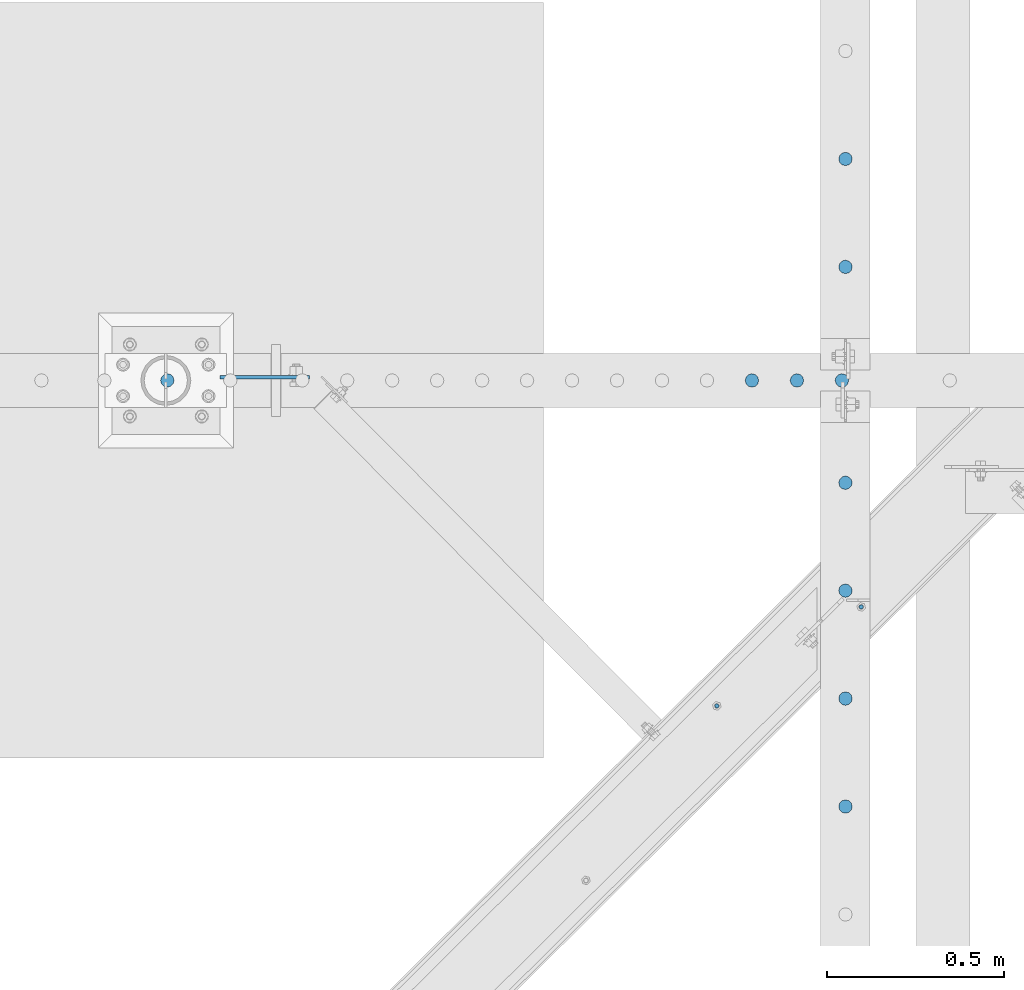
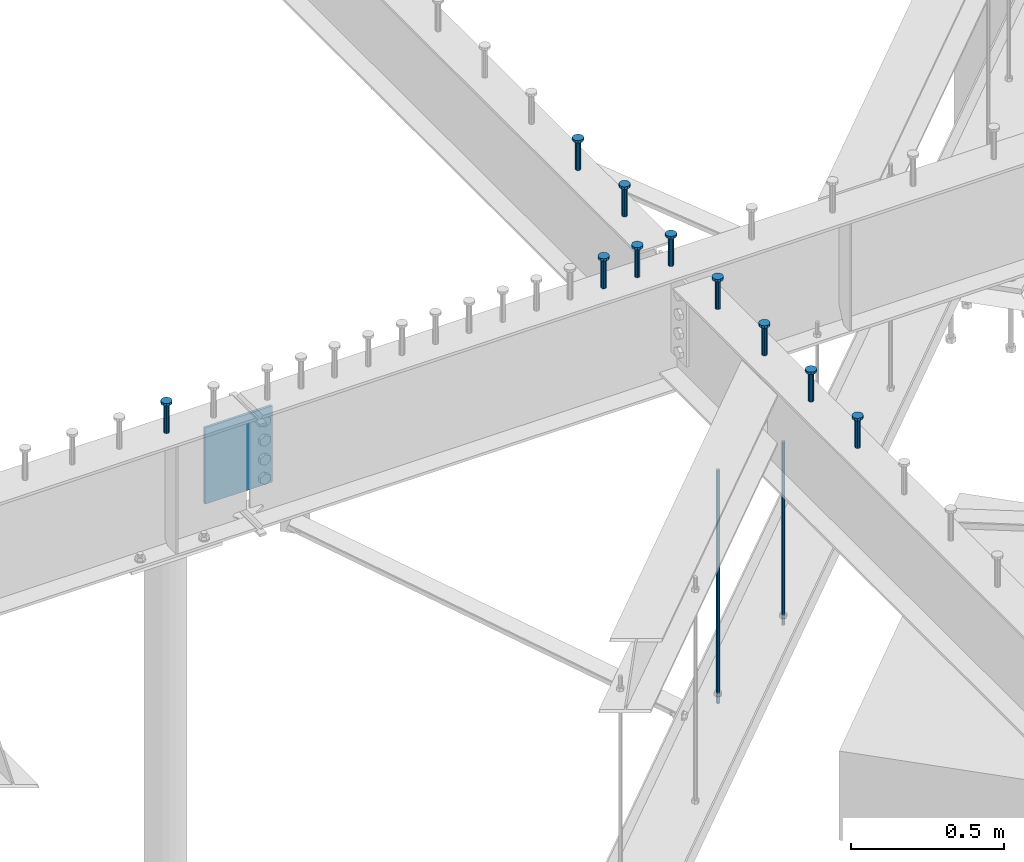
# One storey, part 206 of 975: 13 columns.
"""IFC2X3 building model written with IfcOpenShell, lengths in millimetres."""

from ifc_helpers import new_model, si_unit, frame, origin_with_axes, place, context, subcontext, project, spatial, faceted_brep, material, type_object, element, save


model = new_model("IFC2X3")

# Units and contexts
model_context = context("Model", 3, precision=1e-05, world=origin_with_axes())
body_context = subcontext(model_context, "Body", "Model", "MODEL_VIEW")
ifc_project = project(units=[si_unit("LENGTHUNIT", "METRE", prefix="MILLI"), si_unit("AREAUNIT", "SQUARE_METRE"), si_unit("VOLUMEUNIT", "CUBIC_METRE"), si_unit("MASSUNIT", "GRAM", prefix="KILO"), si_unit("TIMEUNIT", "SECOND"), si_unit("PLANEANGLEUNIT", "RADIAN"), si_unit("SOLIDANGLEUNIT", "STERADIAN"), si_unit("THERMODYNAMICTEMPERATUREUNIT", "DEGREE_CELSIUS"), si_unit("LUMINOUSINTENSITYUNIT", "LUMEN")], contexts=[model_context])

# Site, building, storey
site_placement = place(None, origin_with_axes())
site = spatial("IfcSite", under=ifc_project, at=site_placement, CompositionType="ELEMENT")
building_placement = place(site_placement, origin_with_axes())
building = spatial("IfcBuilding", under=site, at=building_placement, Name="Undefined", CompositionType="ELEMENT")
storey_placement = place(building_placement, origin_with_axes())
storey = spatial("IfcBuildingStorey", under=building, at=storey_placement, Name="Undefined", CompositionType="ELEMENT", Elevation=0.0)

# Columns
ifc_material_1 = material(Name="STEEL/A36")
column_type_1 = type_object("IfcColumnType", PredefinedType="NOTDEFINED")
column_1_placement = place(storey_placement, frame((26689.0500000226, 12752.6443848371, 2870.2), z_axis=(-0.705007718837806, 0.709199630836842, 0.0), x_axis=(0.0, 0.0, 1.0)))
element("IfcColumn", 1, at=column_1_placement, inside=storey, type_object=column_type_1, material=ifc_material_1, Name="ALL-THREAD ROD", context=body_context, shape_type="Brep", body=[
    faceted_brep([(0.0, -6.34999999998763, -3.63797880709171e-12), (0.0, -4.49012806052269, -4.49012806054634), (731.8375, -4.49012806052269, -4.49012806054998), (731.8375, -6.34999999999127, -7.27595761418343e-12), (0.0, 7.27595761418343e-12, -6.35000000000764), (731.8375, 7.27595761418343e-12, -6.35000000000946), (0.0, 4.49012806053724, -4.49012806053906), (731.8375, 4.49012806053724, -4.49012806053906), (0.0, 6.34999999999491, 5.45696821063757e-12), (731.8375, 6.34999999999491, 1.81898940354586e-12), (0.0, 4.49012806052633, 4.49012806054634), (731.8375, 4.49012806052997, 4.49012806054452), (0.0, 0.0, 6.35000000000764), (731.8375, -3.63797880709171e-12, 6.35000000000946), (0.0, -4.49012806053361, 4.49012806053543), (731.8375, -4.49012806052997, 4.49012806053724)], [[[0, 1, 2, 3]], [[1, 4, 5, 2]], [[4, 6, 7, 5]], [[6, 8, 9, 7]], [[8, 10, 11, 9]], [[10, 12, 13, 11]], [[12, 14, 15, 13]], [[14, 0, 3, 15]], [[5, 7, 9, 11, 13, 15, 3, 2]], [[14, 12, 10, 8, 6, 4, 1, 0]]]),
])
column_2_placement = place(storey_placement, frame((26281.5235994516, 12472.939904784, 2870.2), z_axis=(-0.705007718837806, 0.709199630836842, 0.0), x_axis=(0.0, 0.0, 1.0)))
element("IfcColumn", 2, at=column_2_placement, inside=storey, type_object=column_type_1, material=ifc_material_1, Name="ALL-THREAD ROD", context=body_context, shape_type="Brep", body=[
    faceted_brep([(0.0, -6.34999999998763, -3.63797880709171e-12), (0.0, -4.49012806052269, -4.49012806054634), (931.8625, -4.49012806052269, -4.49012806054634), (931.8625, -6.34999999998763, -3.63797880709171e-12), (0.0, 7.27595761418343e-12, -6.35000000000764), (931.8625, 7.27595761418343e-12, -6.35000000000764), (0.0, 4.49012806053724, -4.49012806053906), (931.8625, 4.49012806053724, -4.49012806053906), (0.0, 6.34999999999491, 5.45696821063757e-12), (931.8625, 6.34999999999491, 5.45696821063757e-12), (0.0, 4.49012806052633, 4.49012806054634), (931.8625, 4.49012806052633, 4.49012806054634), (0.0, 0.0, 6.35000000000764), (931.8625, 0.0, 6.35000000000764), (0.0, -4.49012806053361, 4.49012806053543), (931.8625, -4.49012806053361, 4.49012806053543)], [[[0, 1, 2, 3]], [[1, 4, 5, 2]], [[4, 6, 7, 5]], [[6, 8, 9, 7]], [[8, 10, 11, 9]], [[10, 12, 13, 11]], [[12, 14, 15, 13]], [[14, 0, 3, 15]], [[5, 7, 9, 11, 13, 15, 3, 2]], [[14, 12, 10, 8, 6, 4, 1, 0]]]),
])
ifc_material_2 = material(Name="STEEL/A108")
column_type_2 = type_object("IfcColumnType", Name="STUD_3/4-DIA", PredefinedType="NOTDEFINED")
column_3_placement = place(storey_placement, frame((26644.6662714101, 14017.625, 3937.0), z_axis=(0.0, 1.0, 0.0), x_axis=(0.0, 0.0, 1.0)))
element("IfcColumn", 3, at=column_3_placement, inside=storey, type_object=column_type_2, material=ifc_material_2, ObjectType="STUD_3/4-DIA", context=body_context, shape_type="Brep", body=[
    faceted_brep([(0.0, -9.52000045776367, 0.0), (0.0, -8.25, -4.76000022888184), (115.57, -8.25, -4.76000022888184), (115.57, -9.52000045776367, 0.0), (0.0, -4.76000022888184, -8.25), (115.57, -4.76000022888184, -8.25), (0.0, 0.0, -9.52000045776367), (115.57, 0.0, -9.52000045776367), (0.0, 4.76000022888184, -8.25), (115.57, 4.76000022888184, -8.25), (0.0, 8.25, -4.76000022888184), (115.57, 8.25, -4.76000022888184), (0.0, 9.52000045776367, 0.0), (115.57, 9.52000045776367, 0.0), (0.0, 8.25, 4.76000022888184), (115.57, 8.25, 4.76000022888184), (0.0, 4.76000022888184, 8.25), (115.57, 4.76000022888184, 8.25), (0.0, 0.0, 9.52000045776367), (115.57, 0.0, 9.52000045776367), (0.0, -4.76000022888184, 8.25), (115.57, -4.76000022888184, 8.25), (0.0, -8.25, 4.76000022888184), (115.57, -8.25, 4.76000022888184), (116.84, -16.5, -9.52000045776367), (116.84, -19.0499992370605, 0.0), (116.84, -9.52000045776367, -16.5), (116.84, 0.0, -19.0499992370605), (116.84, 9.52000045776367, -16.5), (116.84, 16.5, -9.52000045776367), (116.84, 19.0499992370605, 0.0), (116.84, 16.5, 9.52000045776367), (116.84, 9.52000045776367, 16.5), (116.84, 0.0, 19.0499992370605), (116.84, -9.52000045776367, 16.5), (116.84, -16.5, 9.52000045776367), (127.0, -16.5, -9.52000045776367), (127.0, -19.0499992370605, 0.0), (127.0, -9.52000045776367, -16.5), (127.0, 0.0, -19.0499992370605), (127.0, 9.52000045776367, -16.5), (127.0, 16.5, -9.52000045776367), (127.0, 19.0499992370605, 0.0), (127.0, 16.5, 9.52000045776367), (127.0, 9.52000045776367, 16.5), (127.0, 0.0, 19.0499992370605), (127.0, -9.52000045776367, 16.5), (127.0, -16.5, 9.52000045776367)], [[[0, 1, 2, 3]], [[1, 4, 5, 2]], [[4, 6, 7, 5]], [[6, 8, 9, 7]], [[8, 10, 11, 9]], [[10, 12, 13, 11]], [[12, 14, 15, 13]], [[14, 16, 17, 15]], [[16, 18, 19, 17]], [[18, 20, 21, 19]], [[20, 22, 23, 21]], [[22, 0, 3, 23]], [[22, 20, 18, 16, 14, 12, 10, 8, 6, 4, 1, 0]], [[3, 2, 24, 25]], [[2, 5, 26, 24]], [[5, 7, 27, 26]], [[7, 9, 28, 27]], [[9, 11, 29, 28]], [[11, 13, 30, 29]], [[13, 15, 31, 30]], [[15, 17, 32, 31]], [[17, 19, 33, 32]], [[19, 21, 34, 33]], [[21, 23, 35, 34]], [[23, 3, 25, 35]], [[25, 24, 36, 37]], [[24, 26, 38, 36]], [[26, 27, 39, 38]], [[27, 28, 40, 39]], [[28, 29, 41, 40]], [[29, 30, 42, 41]], [[30, 31, 43, 42]], [[31, 32, 44, 43]], [[32, 33, 45, 44]], [[33, 34, 46, 45]], [[34, 35, 47, 46]], [[35, 25, 37, 47]], [[38, 39, 40, 41, 42, 43, 44, 45, 46, 47, 37, 36]]]),
])
column_4_placement = place(storey_placement, frame((26644.6662714101, 13712.825, 3937.0), z_axis=(0.0, 1.0, 0.0), x_axis=(0.0, 0.0, 1.0)))
element("IfcColumn", 4, at=column_4_placement, inside=storey, type_object=column_type_2, material=ifc_material_2, ObjectType="STUD_3/4-DIA", context=body_context, shape_type="Brep", body=[
    faceted_brep([(0.0, -9.52000045776367, 0.0), (0.0, -8.25, -4.76000022888184), (115.57, -8.25, -4.76000022888184), (115.57, -9.52000045776367, 0.0), (0.0, -4.76000022888184, -8.25), (115.57, -4.76000022888184, -8.25), (0.0, 0.0, -9.52000045776367), (115.57, 0.0, -9.52000045776367), (0.0, 4.76000022888184, -8.25), (115.57, 4.76000022888184, -8.25), (0.0, 8.25, -4.76000022888184), (115.57, 8.25, -4.76000022888184), (0.0, 9.52000045776367, 0.0), (115.57, 9.52000045776367, 0.0), (0.0, 8.25, 4.76000022888184), (115.57, 8.25, 4.76000022888184), (0.0, 4.76000022888184, 8.25), (115.57, 4.76000022888184, 8.25), (0.0, 0.0, 9.52000045776367), (115.57, 0.0, 9.52000045776367), (0.0, -4.76000022888184, 8.25), (115.57, -4.76000022888184, 8.25), (0.0, -8.25, 4.76000022888184), (115.57, -8.25, 4.76000022888184), (116.84, -16.5, -9.52000045776367), (116.84, -19.0499992370605, 0.0), (116.84, -9.52000045776367, -16.5), (116.84, 0.0, -19.0499992370605), (116.84, 9.52000045776367, -16.5), (116.84, 16.5, -9.52000045776367), (116.84, 19.0499992370605, 0.0), (116.84, 16.5, 9.52000045776367), (116.84, 9.52000045776367, 16.5), (116.84, 0.0, 19.0499992370605), (116.84, -9.52000045776367, 16.5), (116.84, -16.5, 9.52000045776367), (127.0, -16.5, -9.52000045776367), (127.0, -19.0499992370605, 0.0), (127.0, -9.52000045776367, -16.5), (127.0, 0.0, -19.0499992370605), (127.0, 9.52000045776367, -16.5), (127.0, 16.5, -9.52000045776367), (127.0, 19.0499992370605, 0.0), (127.0, 16.5, 9.52000045776367), (127.0, 9.52000045776367, 16.5), (127.0, 0.0, 19.0499992370605), (127.0, -9.52000045776367, 16.5), (127.0, -16.5, 9.52000045776367)], [[[0, 1, 2, 3]], [[1, 4, 5, 2]], [[4, 6, 7, 5]], [[6, 8, 9, 7]], [[8, 10, 11, 9]], [[10, 12, 13, 11]], [[12, 14, 15, 13]], [[14, 16, 17, 15]], [[16, 18, 19, 17]], [[18, 20, 21, 19]], [[20, 22, 23, 21]], [[22, 0, 3, 23]], [[22, 20, 18, 16, 14, 12, 10, 8, 6, 4, 1, 0]], [[3, 2, 24, 25]], [[2, 5, 26, 24]], [[5, 7, 27, 26]], [[7, 9, 28, 27]], [[9, 11, 29, 28]], [[11, 13, 30, 29]], [[13, 15, 31, 30]], [[15, 17, 32, 31]], [[17, 19, 33, 32]], [[19, 21, 34, 33]], [[21, 23, 35, 34]], [[23, 3, 25, 35]], [[25, 24, 36, 37]], [[24, 26, 38, 36]], [[26, 27, 39, 38]], [[27, 28, 40, 39]], [[28, 29, 41, 40]], [[29, 30, 42, 41]], [[30, 31, 43, 42]], [[31, 32, 44, 43]], [[32, 33, 45, 44]], [[33, 34, 46, 45]], [[34, 35, 47, 46]], [[35, 25, 37, 47]], [[38, 39, 40, 41, 42, 43, 44, 45, 46, 47, 37, 36]]]),
])
column_5_placement = place(storey_placement, frame((26644.6662714101, 13103.225, 3937.0), z_axis=(0.0, 1.0, 0.0), x_axis=(0.0, 0.0, 1.0)))
element("IfcColumn", 5, at=column_5_placement, inside=storey, type_object=column_type_2, material=ifc_material_2, ObjectType="STUD_3/4-DIA", context=body_context, shape_type="Brep", body=[
    faceted_brep([(0.0, -9.52000045776367, 0.0), (0.0, -8.25, -4.76000022888184), (115.57, -8.25, -4.76000022888184), (115.57, -9.52000045776367, 0.0), (0.0, -4.76000022888184, -8.25), (115.57, -4.76000022888184, -8.25), (0.0, 0.0, -9.52000045776367), (115.57, 0.0, -9.52000045776367), (0.0, 4.76000022888184, -8.25), (115.57, 4.76000022888184, -8.25), (0.0, 8.25, -4.76000022888184), (115.57, 8.25, -4.76000022888184), (0.0, 9.52000045776367, 0.0), (115.57, 9.52000045776367, 0.0), (0.0, 8.25, 4.76000022888184), (115.57, 8.25, 4.76000022888184), (0.0, 4.76000022888184, 8.25), (115.57, 4.76000022888184, 8.25), (0.0, 0.0, 9.52000045776367), (115.57, 0.0, 9.52000045776367), (0.0, -4.76000022888184, 8.25), (115.57, -4.76000022888184, 8.25), (0.0, -8.25, 4.76000022888184), (115.57, -8.25, 4.76000022888184), (116.84, -16.5, -9.52000045776367), (116.84, -19.0499992370605, 0.0), (116.84, -9.52000045776367, -16.5), (116.84, 0.0, -19.0499992370605), (116.84, 9.52000045776367, -16.5), (116.84, 16.5, -9.52000045776367), (116.84, 19.0499992370605, 0.0), (116.84, 16.5, 9.52000045776367), (116.84, 9.52000045776367, 16.5), (116.84, 0.0, 19.0499992370605), (116.84, -9.52000045776367, 16.5), (116.84, -16.5, 9.52000045776367), (127.0, -16.5, -9.52000045776367), (127.0, -19.0499992370605, 0.0), (127.0, -9.52000045776367, -16.5), (127.0, 0.0, -19.0499992370605), (127.0, 9.52000045776367, -16.5), (127.0, 16.5, -9.52000045776367), (127.0, 19.0499992370605, 0.0), (127.0, 16.5, 9.52000045776367), (127.0, 9.52000045776367, 16.5), (127.0, 0.0, 19.0499992370605), (127.0, -9.52000045776367, 16.5), (127.0, -16.5, 9.52000045776367)], [[[0, 1, 2, 3]], [[1, 4, 5, 2]], [[4, 6, 7, 5]], [[6, 8, 9, 7]], [[8, 10, 11, 9]], [[10, 12, 13, 11]], [[12, 14, 15, 13]], [[14, 16, 17, 15]], [[16, 18, 19, 17]], [[18, 20, 21, 19]], [[20, 22, 23, 21]], [[22, 0, 3, 23]], [[22, 20, 18, 16, 14, 12, 10, 8, 6, 4, 1, 0]], [[3, 2, 24, 25]], [[2, 5, 26, 24]], [[5, 7, 27, 26]], [[7, 9, 28, 27]], [[9, 11, 29, 28]], [[11, 13, 30, 29]], [[13, 15, 31, 30]], [[15, 17, 32, 31]], [[17, 19, 33, 32]], [[19, 21, 34, 33]], [[21, 23, 35, 34]], [[23, 3, 25, 35]], [[25, 24, 36, 37]], [[24, 26, 38, 36]], [[26, 27, 39, 38]], [[27, 28, 40, 39]], [[28, 29, 41, 40]], [[29, 30, 42, 41]], [[30, 31, 43, 42]], [[31, 32, 44, 43]], [[32, 33, 45, 44]], [[33, 34, 46, 45]], [[34, 35, 47, 46]], [[35, 25, 37, 47]], [[38, 39, 40, 41, 42, 43, 44, 45, 46, 47, 37, 36]]]),
])
column_6_placement = place(storey_placement, frame((26644.6662714101, 12798.425, 3937.0), z_axis=(0.0, 1.0, 0.0), x_axis=(0.0, 0.0, 1.0)))
element("IfcColumn", 6, at=column_6_placement, inside=storey, type_object=column_type_2, material=ifc_material_2, ObjectType="STUD_3/4-DIA", context=body_context, shape_type="Brep", body=[
    faceted_brep([(0.0, -9.52000045776367, 0.0), (0.0, -8.25, -4.76000022888184), (115.57, -8.25, -4.76000022888184), (115.57, -9.52000045776367, 0.0), (0.0, -4.76000022888184, -8.25), (115.57, -4.76000022888184, -8.25), (0.0, 0.0, -9.52000045776367), (115.57, 0.0, -9.52000045776367), (0.0, 4.76000022888184, -8.25), (115.57, 4.76000022888184, -8.25), (0.0, 8.25, -4.76000022888184), (115.57, 8.25, -4.76000022888184), (0.0, 9.52000045776367, 0.0), (115.57, 9.52000045776367, 0.0), (0.0, 8.25, 4.76000022888184), (115.57, 8.25, 4.76000022888184), (0.0, 4.76000022888184, 8.25), (115.57, 4.76000022888184, 8.25), (0.0, 0.0, 9.52000045776367), (115.57, 0.0, 9.52000045776367), (0.0, -4.76000022888184, 8.25), (115.57, -4.76000022888184, 8.25), (0.0, -8.25, 4.76000022888184), (115.57, -8.25, 4.76000022888184), (116.84, -16.5, -9.52000045776367), (116.84, -19.0499992370605, 0.0), (116.84, -9.52000045776367, -16.5), (116.84, 0.0, -19.0499992370605), (116.84, 9.52000045776367, -16.5), (116.84, 16.5, -9.52000045776367), (116.84, 19.0499992370605, 0.0), (116.84, 16.5, 9.52000045776367), (116.84, 9.52000045776367, 16.5), (116.84, 0.0, 19.0499992370605), (116.84, -9.52000045776367, 16.5), (116.84, -16.5, 9.52000045776367), (127.0, -16.5, -9.52000045776367), (127.0, -19.0499992370605, 0.0), (127.0, -9.52000045776367, -16.5), (127.0, 0.0, -19.0499992370605), (127.0, 9.52000045776367, -16.5), (127.0, 16.5, -9.52000045776367), (127.0, 19.0499992370605, 0.0), (127.0, 16.5, 9.52000045776367), (127.0, 9.52000045776367, 16.5), (127.0, 0.0, 19.0499992370605), (127.0, -9.52000045776367, 16.5), (127.0, -16.5, 9.52000045776367)], [[[0, 1, 2, 3]], [[1, 4, 5, 2]], [[4, 6, 7, 5]], [[6, 8, 9, 7]], [[8, 10, 11, 9]], [[10, 12, 13, 11]], [[12, 14, 15, 13]], [[14, 16, 17, 15]], [[16, 18, 19, 17]], [[18, 20, 21, 19]], [[20, 22, 23, 21]], [[22, 0, 3, 23]], [[22, 20, 18, 16, 14, 12, 10, 8, 6, 4, 1, 0]], [[3, 2, 24, 25]], [[2, 5, 26, 24]], [[5, 7, 27, 26]], [[7, 9, 28, 27]], [[9, 11, 29, 28]], [[11, 13, 30, 29]], [[13, 15, 31, 30]], [[15, 17, 32, 31]], [[17, 19, 33, 32]], [[19, 21, 34, 33]], [[21, 23, 35, 34]], [[23, 3, 25, 35]], [[25, 24, 36, 37]], [[24, 26, 38, 36]], [[26, 27, 39, 38]], [[27, 28, 40, 39]], [[28, 29, 41, 40]], [[29, 30, 42, 41]], [[30, 31, 43, 42]], [[31, 32, 44, 43]], [[32, 33, 45, 44]], [[33, 34, 46, 45]], [[34, 35, 47, 46]], [[35, 25, 37, 47]], [[38, 39, 40, 41, 42, 43, 44, 45, 46, 47, 37, 36]]]),
])
column_7_placement = place(storey_placement, frame((26644.6662714101, 12493.625, 3937.0), z_axis=(0.0, 1.0, 0.0), x_axis=(0.0, 0.0, 1.0)))
element("IfcColumn", 7, at=column_7_placement, inside=storey, type_object=column_type_2, material=ifc_material_2, ObjectType="STUD_3/4-DIA", context=body_context, shape_type="Brep", body=[
    faceted_brep([(0.0, -9.52000045776367, 0.0), (0.0, -8.25, -4.76000022888184), (115.57, -8.25, -4.76000022888184), (115.57, -9.52000045776367, 0.0), (0.0, -4.76000022888184, -8.25), (115.57, -4.76000022888184, -8.25), (0.0, 0.0, -9.52000045776367), (115.57, 0.0, -9.52000045776367), (0.0, 4.76000022888184, -8.25), (115.57, 4.76000022888184, -8.25), (0.0, 8.25, -4.76000022888184), (115.57, 8.25, -4.76000022888184), (0.0, 9.52000045776367, 0.0), (115.57, 9.52000045776367, 0.0), (0.0, 8.25, 4.76000022888184), (115.57, 8.25, 4.76000022888184), (0.0, 4.76000022888184, 8.25), (115.57, 4.76000022888184, 8.25), (0.0, 0.0, 9.52000045776367), (115.57, 0.0, 9.52000045776367), (0.0, -4.76000022888184, 8.25), (115.57, -4.76000022888184, 8.25), (0.0, -8.25, 4.76000022888184), (115.57, -8.25, 4.76000022888184), (116.84, -16.5, -9.52000045776367), (116.84, -19.0499992370605, 0.0), (116.84, -9.52000045776367, -16.5), (116.84, 0.0, -19.0499992370605), (116.84, 9.52000045776367, -16.5), (116.84, 16.5, -9.52000045776367), (116.84, 19.0499992370605, 0.0), (116.84, 16.5, 9.52000045776367), (116.84, 9.52000045776367, 16.5), (116.84, 0.0, 19.0499992370605), (116.84, -9.52000045776367, 16.5), (116.84, -16.5, 9.52000045776367), (127.0, -16.5, -9.52000045776367), (127.0, -19.0499992370605, 0.0), (127.0, -9.52000045776367, -16.5), (127.0, 0.0, -19.0499992370605), (127.0, 9.52000045776367, -16.5), (127.0, 16.5, -9.52000045776367), (127.0, 19.0499992370605, 0.0), (127.0, 16.5, 9.52000045776367), (127.0, 9.52000045776367, 16.5), (127.0, 0.0, 19.0499992370605), (127.0, -9.52000045776367, 16.5), (127.0, -16.5, 9.52000045776367)], [[[0, 1, 2, 3]], [[1, 4, 5, 2]], [[4, 6, 7, 5]], [[6, 8, 9, 7]], [[8, 10, 11, 9]], [[10, 12, 13, 11]], [[12, 14, 15, 13]], [[14, 16, 17, 15]], [[16, 18, 19, 17]], [[18, 20, 21, 19]], [[20, 22, 23, 21]], [[22, 0, 3, 23]], [[22, 20, 18, 16, 14, 12, 10, 8, 6, 4, 1, 0]], [[3, 2, 24, 25]], [[2, 5, 26, 24]], [[5, 7, 27, 26]], [[7, 9, 28, 27]], [[9, 11, 29, 28]], [[11, 13, 30, 29]], [[13, 15, 31, 30]], [[15, 17, 32, 31]], [[17, 19, 33, 32]], [[19, 21, 34, 33]], [[21, 23, 35, 34]], [[23, 3, 25, 35]], [[25, 24, 36, 37]], [[24, 26, 38, 36]], [[26, 27, 39, 38]], [[27, 28, 40, 39]], [[28, 29, 41, 40]], [[29, 30, 42, 41]], [[30, 31, 43, 42]], [[31, 32, 44, 43]], [[32, 33, 45, 44]], [[33, 34, 46, 45]], [[34, 35, 47, 46]], [[35, 25, 37, 47]], [[38, 39, 40, 41, 42, 43, 44, 45, 46, 47, 37, 36]]]),
])
column_8_placement = place(storey_placement, frame((26644.6662714101, 12188.825, 3937.0), z_axis=(0.0, 1.0, 0.0), x_axis=(0.0, 0.0, 1.0)))
element("IfcColumn", 8, at=column_8_placement, inside=storey, type_object=column_type_2, material=ifc_material_2, ObjectType="STUD_3/4-DIA", context=body_context, shape_type="Brep", body=[
    faceted_brep([(0.0, -9.52000045776367, 0.0), (0.0, -8.25, -4.76000022888184), (115.57, -8.25, -4.76000022888184), (115.57, -9.52000045776367, 0.0), (0.0, -4.76000022888184, -8.25), (115.57, -4.76000022888184, -8.25), (0.0, 0.0, -9.52000045776367), (115.57, 0.0, -9.52000045776367), (0.0, 4.76000022888184, -8.25), (115.57, 4.76000022888184, -8.25), (0.0, 8.25, -4.76000022888184), (115.57, 8.25, -4.76000022888184), (0.0, 9.52000045776367, 0.0), (115.57, 9.52000045776367, 0.0), (0.0, 8.25, 4.76000022888184), (115.57, 8.25, 4.76000022888184), (0.0, 4.76000022888184, 8.25), (115.57, 4.76000022888184, 8.25), (0.0, 0.0, 9.52000045776367), (115.57, 0.0, 9.52000045776367), (0.0, -4.76000022888184, 8.25), (115.57, -4.76000022888184, 8.25), (0.0, -8.25, 4.76000022888184), (115.57, -8.25, 4.76000022888184), (116.84, -16.5, -9.52000045776367), (116.84, -19.0499992370605, 0.0), (116.84, -9.52000045776367, -16.5), (116.84, 0.0, -19.0499992370605), (116.84, 9.52000045776367, -16.5), (116.84, 16.5, -9.52000045776367), (116.84, 19.0499992370605, 0.0), (116.84, 16.5, 9.52000045776367), (116.84, 9.52000045776367, 16.5), (116.84, 0.0, 19.0499992370605), (116.84, -9.52000045776367, 16.5), (116.84, -16.5, 9.52000045776367), (127.0, -16.5, -9.52000045776367), (127.0, -19.0499992370605, 0.0), (127.0, -9.52000045776367, -16.5), (127.0, 0.0, -19.0499992370605), (127.0, 9.52000045776367, -16.5), (127.0, 16.5, -9.52000045776367), (127.0, 19.0499992370605, 0.0), (127.0, 16.5, 9.52000045776367), (127.0, 9.52000045776367, 16.5), (127.0, 0.0, 19.0499992370605), (127.0, -9.52000045776367, 16.5), (127.0, -16.5, 9.52000045776367)], [[[0, 1, 2, 3]], [[1, 4, 5, 2]], [[4, 6, 7, 5]], [[6, 8, 9, 7]], [[8, 10, 11, 9]], [[10, 12, 13, 11]], [[12, 14, 15, 13]], [[14, 16, 17, 15]], [[16, 18, 19, 17]], [[18, 20, 21, 19]], [[20, 22, 23, 21]], [[22, 0, 3, 23]], [[22, 20, 18, 16, 14, 12, 10, 8, 6, 4, 1, 0]], [[3, 2, 24, 25]], [[2, 5, 26, 24]], [[5, 7, 27, 26]], [[7, 9, 28, 27]], [[9, 11, 29, 28]], [[11, 13, 30, 29]], [[13, 15, 31, 30]], [[15, 17, 32, 31]], [[17, 19, 33, 32]], [[19, 21, 34, 33]], [[21, 23, 35, 34]], [[23, 3, 25, 35]], [[25, 24, 36, 37]], [[24, 26, 38, 36]], [[26, 27, 39, 38]], [[27, 28, 40, 39]], [[28, 29, 41, 40]], [[29, 30, 42, 41]], [[30, 31, 43, 42]], [[31, 32, 44, 43]], [[32, 33, 45, 44]], [[33, 34, 46, 45]], [[34, 35, 47, 46]], [[35, 25, 37, 47]], [[38, 39, 40, 41, 42, 43, 44, 45, 46, 47, 37, 36]]]),
])
column_9_placement = place(storey_placement, frame((26634.5459584101, 13392.15, 3937.0), z_axis=(0.0, 1.0, 0.0), x_axis=(0.0, 0.0, 1.0)))
element("IfcColumn", 9, at=column_9_placement, inside=storey, type_object=column_type_2, material=ifc_material_2, ObjectType="STUD_3/4-DIA", context=body_context, shape_type="Brep", body=[
    faceted_brep([(0.0, -9.52000045776367, 0.0), (0.0, -8.25, -4.76000022888184), (115.57, -8.25, -4.76000022888184), (115.57, -9.52000045776367, 0.0), (0.0, -4.76000022888184, -8.25), (115.57, -4.76000022888184, -8.25), (0.0, 0.0, -9.52000045776367), (115.57, 0.0, -9.52000045776367), (0.0, 4.76000022888184, -8.25), (115.57, 4.76000022888184, -8.25), (0.0, 8.25, -4.76000022888184), (115.57, 8.25, -4.76000022888184), (0.0, 9.52000045776367, 0.0), (115.57, 9.52000045776367, 0.0), (0.0, 8.25, 4.76000022888184), (115.57, 8.25, 4.76000022888184), (0.0, 4.76000022888184, 8.25), (115.57, 4.76000022888184, 8.25), (0.0, 0.0, 9.52000045776367), (115.57, 0.0, 9.52000045776367), (0.0, -4.76000022888184, 8.25), (115.57, -4.76000022888184, 8.25), (0.0, -8.25, 4.76000022888184), (115.57, -8.25, 4.76000022888184), (116.84, -16.5, -9.52000045776367), (116.84, -19.0499992370605, 0.0), (116.84, -9.52000045776367, -16.5), (116.84, 0.0, -19.0499992370605), (116.84, 9.52000045776367, -16.5), (116.84, 16.5, -9.52000045776367), (116.84, 19.0499992370605, 0.0), (116.84, 16.5, 9.52000045776367), (116.84, 9.52000045776367, 16.5), (116.84, 0.0, 19.0499992370605), (116.84, -9.52000045776367, 16.5), (116.84, -16.5, 9.52000045776367), (127.0, -16.5, -9.52000045776367), (127.0, -19.0499992370605, 0.0), (127.0, -9.52000045776367, -16.5), (127.0, 0.0, -19.0499992370605), (127.0, 9.52000045776367, -16.5), (127.0, 16.5, -9.52000045776367), (127.0, 19.0499992370605, 0.0), (127.0, 16.5, 9.52000045776367), (127.0, 9.52000045776367, 16.5), (127.0, 0.0, 19.0499992370605), (127.0, -9.52000045776367, 16.5), (127.0, -16.5, 9.52000045776367)], [[[0, 1, 2, 3]], [[1, 4, 5, 2]], [[4, 6, 7, 5]], [[6, 8, 9, 7]], [[8, 10, 11, 9]], [[10, 12, 13, 11]], [[12, 14, 15, 13]], [[14, 16, 17, 15]], [[16, 18, 19, 17]], [[18, 20, 21, 19]], [[20, 22, 23, 21]], [[22, 0, 3, 23]], [[22, 20, 18, 16, 14, 12, 10, 8, 6, 4, 1, 0]], [[3, 2, 24, 25]], [[2, 5, 26, 24]], [[5, 7, 27, 26]], [[7, 9, 28, 27]], [[9, 11, 29, 28]], [[11, 13, 30, 29]], [[13, 15, 31, 30]], [[15, 17, 32, 31]], [[17, 19, 33, 32]], [[19, 21, 34, 33]], [[21, 23, 35, 34]], [[23, 3, 25, 35]], [[25, 24, 36, 37]], [[24, 26, 38, 36]], [[26, 27, 39, 38]], [[27, 28, 40, 39]], [[28, 29, 41, 40]], [[29, 30, 42, 41]], [[30, 31, 43, 42]], [[31, 32, 44, 43]], [[32, 33, 45, 44]], [[33, 34, 46, 45]], [[34, 35, 47, 46]], [[35, 25, 37, 47]], [[38, 39, 40, 41, 42, 43, 44, 45, 46, 47, 37, 36]]]),
])
column_10_placement = place(storey_placement, frame((26507.5459584101, 13392.15, 3937.0), z_axis=(0.0, 1.0, 0.0), x_axis=(0.0, 0.0, 1.0)))
element("IfcColumn", 10, at=column_10_placement, inside=storey, type_object=column_type_2, material=ifc_material_2, ObjectType="STUD_3/4-DIA", context=body_context, shape_type="Brep", body=[
    faceted_brep([(0.0, -9.52000045776367, 0.0), (0.0, -8.25, -4.76000022888184), (115.57, -8.25, -4.76000022888184), (115.57, -9.52000045776367, 0.0), (0.0, -4.76000022888184, -8.25), (115.57, -4.76000022888184, -8.25), (0.0, 0.0, -9.52000045776367), (115.57, 0.0, -9.52000045776367), (0.0, 4.76000022888184, -8.25), (115.57, 4.76000022888184, -8.25), (0.0, 8.25, -4.76000022888184), (115.57, 8.25, -4.76000022888184), (0.0, 9.52000045776367, 0.0), (115.57, 9.52000045776367, 0.0), (0.0, 8.25, 4.76000022888184), (115.57, 8.25, 4.76000022888184), (0.0, 4.76000022888184, 8.25), (115.57, 4.76000022888184, 8.25), (0.0, 0.0, 9.52000045776367), (115.57, 0.0, 9.52000045776367), (0.0, -4.76000022888184, 8.25), (115.57, -4.76000022888184, 8.25), (0.0, -8.25, 4.76000022888184), (115.57, -8.25, 4.76000022888184), (116.84, -16.5, -9.52000045776367), (116.84, -19.0499992370605, 0.0), (116.84, -9.52000045776367, -16.5), (116.84, 0.0, -19.0499992370605), (116.84, 9.52000045776367, -16.5), (116.84, 16.5, -9.52000045776367), (116.84, 19.0499992370605, 0.0), (116.84, 16.5, 9.52000045776367), (116.84, 9.52000045776367, 16.5), (116.84, 0.0, 19.0499992370605), (116.84, -9.52000045776367, 16.5), (116.84, -16.5, 9.52000045776367), (127.0, -16.5, -9.52000045776367), (127.0, -19.0499992370605, 0.0), (127.0, -9.52000045776367, -16.5), (127.0, 0.0, -19.0499992370605), (127.0, 9.52000045776367, -16.5), (127.0, 16.5, -9.52000045776367), (127.0, 19.0499992370605, 0.0), (127.0, 16.5, 9.52000045776367), (127.0, 9.52000045776367, 16.5), (127.0, 0.0, 19.0499992370605), (127.0, -9.52000045776367, 16.5), (127.0, -16.5, 9.52000045776367)], [[[0, 1, 2, 3]], [[1, 4, 5, 2]], [[4, 6, 7, 5]], [[6, 8, 9, 7]], [[8, 10, 11, 9]], [[10, 12, 13, 11]], [[12, 14, 15, 13]], [[14, 16, 17, 15]], [[16, 18, 19, 17]], [[18, 20, 21, 19]], [[20, 22, 23, 21]], [[22, 0, 3, 23]], [[22, 20, 18, 16, 14, 12, 10, 8, 6, 4, 1, 0]], [[3, 2, 24, 25]], [[2, 5, 26, 24]], [[5, 7, 27, 26]], [[7, 9, 28, 27]], [[9, 11, 29, 28]], [[11, 13, 30, 29]], [[13, 15, 31, 30]], [[15, 17, 32, 31]], [[17, 19, 33, 32]], [[19, 21, 34, 33]], [[21, 23, 35, 34]], [[23, 3, 25, 35]], [[25, 24, 36, 37]], [[24, 26, 38, 36]], [[26, 27, 39, 38]], [[27, 28, 40, 39]], [[28, 29, 41, 40]], [[29, 30, 42, 41]], [[30, 31, 43, 42]], [[31, 32, 44, 43]], [[32, 33, 45, 44]], [[33, 34, 46, 45]], [[34, 35, 47, 46]], [[35, 25, 37, 47]], [[38, 39, 40, 41, 42, 43, 44, 45, 46, 47, 37, 36]]]),
])
column_11_placement = place(storey_placement, frame((26380.5459584101, 13392.15, 3937.0), z_axis=(0.0, 1.0, 0.0), x_axis=(0.0, 0.0, 1.0)))
element("IfcColumn", 11, at=column_11_placement, inside=storey, type_object=column_type_2, material=ifc_material_2, ObjectType="STUD_3/4-DIA", context=body_context, shape_type="Brep", body=[
    faceted_brep([(0.0, -9.52000045776367, 0.0), (0.0, -8.25, -4.76000022888184), (115.57, -8.25, -4.76000022888184), (115.57, -9.52000045776367, 0.0), (0.0, -4.76000022888184, -8.25), (115.57, -4.76000022888184, -8.25), (0.0, 0.0, -9.52000045776367), (115.57, 0.0, -9.52000045776367), (0.0, 4.76000022888184, -8.25), (115.57, 4.76000022888184, -8.25), (0.0, 8.25, -4.76000022888184), (115.57, 8.25, -4.76000022888184), (0.0, 9.52000045776367, 0.0), (115.57, 9.52000045776367, 0.0), (0.0, 8.25, 4.76000022888184), (115.57, 8.25, 4.76000022888184), (0.0, 4.76000022888184, 8.25), (115.57, 4.76000022888184, 8.25), (0.0, 0.0, 9.52000045776367), (115.57, 0.0, 9.52000045776367), (0.0, -4.76000022888184, 8.25), (115.57, -4.76000022888184, 8.25), (0.0, -8.25, 4.76000022888184), (115.57, -8.25, 4.76000022888184), (116.84, -16.5, -9.52000045776367), (116.84, -19.0499992370605, 0.0), (116.84, -9.52000045776367, -16.5), (116.84, 0.0, -19.0499992370605), (116.84, 9.52000045776367, -16.5), (116.84, 16.5, -9.52000045776367), (116.84, 19.0499992370605, 0.0), (116.84, 16.5, 9.52000045776367), (116.84, 9.52000045776367, 16.5), (116.84, 0.0, 19.0499992370605), (116.84, -9.52000045776367, 16.5), (116.84, -16.5, 9.52000045776367), (127.0, -16.5, -9.52000045776367), (127.0, -19.0499992370605, 0.0), (127.0, -9.52000045776367, -16.5), (127.0, 0.0, -19.0499992370605), (127.0, 9.52000045776367, -16.5), (127.0, 16.5, -9.52000045776367), (127.0, 19.0499992370605, 0.0), (127.0, 16.5, 9.52000045776367), (127.0, 9.52000045776367, 16.5), (127.0, 0.0, 19.0499992370605), (127.0, -9.52000045776367, 16.5), (127.0, -16.5, 9.52000045776367)], [[[0, 1, 2, 3]], [[1, 4, 5, 2]], [[4, 6, 7, 5]], [[6, 8, 9, 7]], [[8, 10, 11, 9]], [[10, 12, 13, 11]], [[12, 14, 15, 13]], [[14, 16, 17, 15]], [[16, 18, 19, 17]], [[18, 20, 21, 19]], [[20, 22, 23, 21]], [[22, 0, 3, 23]], [[22, 20, 18, 16, 14, 12, 10, 8, 6, 4, 1, 0]], [[3, 2, 24, 25]], [[2, 5, 26, 24]], [[5, 7, 27, 26]], [[7, 9, 28, 27]], [[9, 11, 29, 28]], [[11, 13, 30, 29]], [[13, 15, 31, 30]], [[15, 17, 32, 31]], [[17, 19, 33, 32]], [[19, 21, 34, 33]], [[21, 23, 35, 34]], [[23, 3, 25, 35]], [[25, 24, 36, 37]], [[24, 26, 38, 36]], [[26, 27, 39, 38]], [[27, 28, 40, 39]], [[28, 29, 41, 40]], [[29, 30, 42, 41]], [[30, 31, 43, 42]], [[31, 32, 44, 43]], [[32, 33, 45, 44]], [[33, 34, 46, 45]], [[34, 35, 47, 46]], [[35, 25, 37, 47]], [[38, 39, 40, 41, 42, 43, 44, 45, 46, 47, 37, 36]]]),
])
column_12_placement = place(storey_placement, frame((24729.5459584101, 13392.15, 3937.0), z_axis=(0.0, 1.0, 0.0), x_axis=(0.0, 0.0, 1.0)))
element("IfcColumn", 12, at=column_12_placement, inside=storey, type_object=column_type_2, material=ifc_material_2, ObjectType="STUD_3/4-DIA", context=body_context, shape_type="Brep", body=[
    faceted_brep([(0.0, -9.52000045776367, 0.0), (0.0, -8.25, -4.76000022888184), (115.57, -8.25, -4.76000022888184), (115.57, -9.52000045776367, 0.0), (0.0, -4.76000022888184, -8.25), (115.57, -4.76000022888184, -8.25), (0.0, 0.0, -9.52000045776367), (115.57, 0.0, -9.52000045776367), (0.0, 4.76000022888184, -8.25), (115.57, 4.76000022888184, -8.25), (0.0, 8.25, -4.76000022888184), (115.57, 8.25, -4.76000022888184), (0.0, 9.52000045776367, 0.0), (115.57, 9.52000045776367, 0.0), (0.0, 8.25, 4.76000022888184), (115.57, 8.25, 4.76000022888184), (0.0, 4.76000022888184, 8.25), (115.57, 4.76000022888184, 8.25), (0.0, 0.0, 9.52000045776367), (115.57, 0.0, 9.52000045776367), (0.0, -4.76000022888184, 8.25), (115.57, -4.76000022888184, 8.25), (0.0, -8.25, 4.76000022888184), (115.57, -8.25, 4.76000022888184), (116.84, -16.5, -9.52000045776367), (116.84, -19.0499992370605, 0.0), (116.84, -9.52000045776367, -16.5), (116.84, 0.0, -19.0499992370605), (116.84, 9.52000045776367, -16.5), (116.84, 16.5, -9.52000045776367), (116.84, 19.0499992370605, 0.0), (116.84, 16.5, 9.52000045776367), (116.84, 9.52000045776367, 16.5), (116.84, 0.0, 19.0499992370605), (116.84, -9.52000045776367, 16.5), (116.84, -16.5, 9.52000045776367), (127.0, -16.5, -9.52000045776367), (127.0, -19.0499992370605, 0.0), (127.0, -9.52000045776367, -16.5), (127.0, 0.0, -19.0499992370605), (127.0, 9.52000045776367, -16.5), (127.0, 16.5, -9.52000045776367), (127.0, 19.0499992370605, 0.0), (127.0, 16.5, 9.52000045776367), (127.0, 9.52000045776367, 16.5), (127.0, 0.0, 19.0499992370605), (127.0, -9.52000045776367, 16.5), (127.0, -16.5, 9.52000045776367)], [[[0, 1, 2, 3]], [[1, 4, 5, 2]], [[4, 6, 7, 5]], [[6, 8, 9, 7]], [[8, 10, 11, 9]], [[10, 12, 13, 11]], [[12, 14, 15, 13]], [[14, 16, 17, 15]], [[16, 18, 19, 17]], [[18, 20, 21, 19]], [[20, 22, 23, 21]], [[22, 0, 3, 23]], [[22, 20, 18, 16, 14, 12, 10, 8, 6, 4, 1, 0]], [[3, 2, 24, 25]], [[2, 5, 26, 24]], [[5, 7, 27, 26]], [[7, 9, 28, 27]], [[9, 11, 29, 28]], [[11, 13, 30, 29]], [[13, 15, 31, 30]], [[15, 17, 32, 31]], [[17, 19, 33, 32]], [[19, 21, 34, 33]], [[21, 23, 35, 34]], [[23, 3, 25, 35]], [[25, 24, 36, 37]], [[24, 26, 38, 36]], [[26, 27, 39, 38]], [[27, 28, 40, 39]], [[28, 29, 41, 40]], [[29, 30, 42, 41]], [[30, 31, 43, 42]], [[31, 32, 44, 43]], [[32, 33, 45, 44]], [[33, 34, 46, 45]], [[34, 35, 47, 46]], [[35, 25, 37, 47]], [[38, 39, 40, 41, 42, 43, 44, 45, 46, 47, 37, 36]]]),
])
column_type_3 = type_object("IfcColumnType", PredefinedType="NOTDEFINED")
column_13_placement = place(storey_placement, frame((25004.7125, 13400.88125, 3594.1), z_axis=(-0.999999999999998, 6.90000001668524e-08, 0.0), x_axis=(0.0, 0.0, 1.0)))
element("IfcColumn", 13, at=column_13_placement, inside=storey, type_object=column_type_3, material=ifc_material_1, Name="PLATE", context=body_context, shape_type="Brep", body=[
    faceted_brep([(0.0, 4.76250000000073, -127.0), (2.26333322643768e-05, 4.76250000029177, 127.000000000276), (304.8, 4.76250000000073, 127.0), (304.8, 4.76250000000073, -127.0), (2.26333322643768e-05, -4.76249999968422, 127.000000000295), (304.8, -4.76250000000073, 127.0), (0.0, -4.76250000000073, -127.0), (304.8, -4.76250000000073, -127.0)], [[[0, 1, 2, 3]], [[1, 4, 5, 2]], [[4, 6, 7, 5]], [[6, 0, 3, 7]], [[5, 7, 3, 2]], [[6, 4, 1, 0]]]),
])

save(model, "model.ifc")
